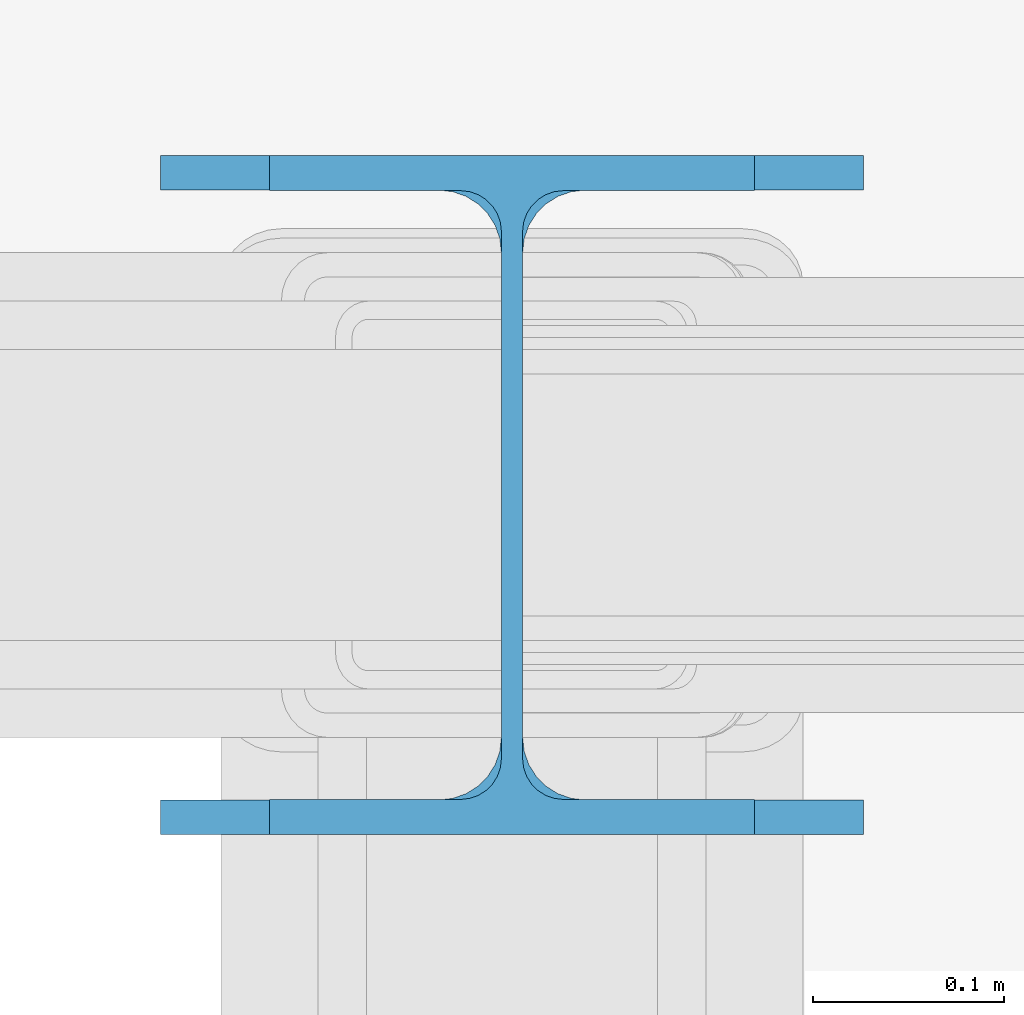
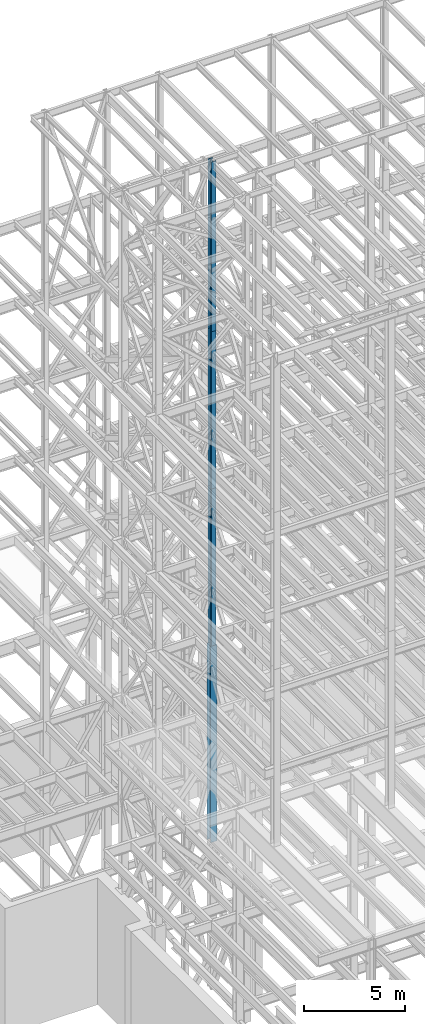
# One storey, part 17 of 150: 4 columns.
"""IFC2X3 building model written with IfcOpenShell, lengths in millimetres."""

from ifc_helpers import new_model, si_unit, frame, origin_with_axes, origin_2d_with_axis, place, context, subcontext, project, spatial, i_section, extrude, material, type_object, element, save


model = new_model("IFC2X3")

# Units and contexts
model_context = context("Model", 3, precision=1e-05, world=origin_with_axes())
body_context = subcontext(model_context, "Body", "Model", "MODEL_VIEW")
ifc_project = project(units=[si_unit("LENGTHUNIT", "METRE", prefix="MILLI"), si_unit("AREAUNIT", "SQUARE_METRE"), si_unit("VOLUMEUNIT", "CUBIC_METRE"), si_unit("MASSUNIT", "GRAM", prefix="KILO"), si_unit("TIMEUNIT", "SECOND"), si_unit("PLANEANGLEUNIT", "RADIAN"), si_unit("SOLIDANGLEUNIT", "STERADIAN"), si_unit("THERMODYNAMICTEMPERATUREUNIT", "DEGREE_CELSIUS"), si_unit("LUMINOUSINTENSITYUNIT", "LUMEN")], contexts=[model_context])

# Site, building, storey
site_placement = place(None, origin_with_axes())
site = spatial("IfcSite", under=ifc_project, at=site_placement, CompositionType="ELEMENT")
building_placement = place(site_placement, origin_with_axes())
building = spatial("IfcBuilding", under=site, at=building_placement, Name="Undefined", CompositionType="ELEMENT")
storey_placement = place(building_placement, origin_with_axes())
storey = spatial("IfcBuildingStorey", under=building, at=storey_placement, Name="Undefined", CompositionType="ELEMENT", Elevation=0.0)

# Columns
ifc_material = material(Name="STEEL/A992")
column_type_1 = type_object("IfcColumnType", Name="W14X68", PredefinedType="NOTDEFINED")
column_1_placement = place(storey_placement, frame((10312.39949708, 24384.0, 55702.2), z_axis=(0.0, 0.0, 1.0), x_axis=(1.0, 0.0, 0.0)))
element("IfcColumn", 1, at=column_1_placement, inside=storey, type_object=column_type_1, material=ifc_material, Name="COLUMN", ObjectType="W14X68", context=body_context, shape_type="SweptSolid", body=[
    extrude(i_section(OverallWidth=254.0, OverallDepth=355.6, WebThickness=11.1125, FlangeThickness=18.288, FilletRadius=21.3994, at=origin_2d_with_axis()), frame((0.0, 0.0, 10210.8), z_axis=(0.0, 0.0, -1.0), x_axis=(-1.0, 0.0, 0.0)), (0.0, 0.0, 1.0), 10210.8),
])
for number, where, z_axis, x_axis, name in (
    (2, (10312.39949708, 24384.0, 46253.4), (0.0, 0.0, 1.0), (1.0, 0.0, 0.0), "COLUMN"),
    (3, (10312.39949708, 24384.0, 36804.6), (0.0, 0.0, 1.0), (1.0, 0.0, 0.0), "COLUMN"),
):
    element("IfcColumn", number, at=place(storey_placement, frame(where, z_axis=z_axis, x_axis=x_axis)), inside=storey, type_object=column_type_1, material=ifc_material, Name=name, ObjectType="W14X68", context=body_context, shape_type="SweptSolid", body=[
        extrude(i_section(OverallWidth=254.0, OverallDepth=355.6, WebThickness=11.1125, FlangeThickness=18.288, FilletRadius=21.3994, at=origin_2d_with_axis()), frame((0.0, 0.0, 9448.8), z_axis=(0.0, 0.0, -1.0), x_axis=(-1.0, 0.0, 0.0)), (0.0, 0.0, 1.0), 9448.8),
    ])
column_type_2 = type_object("IfcColumnType", Name="W14X90", PredefinedType="NOTDEFINED")
column_2_placement = place(storey_placement, frame((10312.39949708, 24384.0, 24993.6), z_axis=(0.0, 0.0, 1.0), x_axis=(1.0, 0.0, 0.0)))
element("IfcColumn", 4, at=column_2_placement, inside=storey, type_object=column_type_2, material=ifc_material, Name="COLUMN", ObjectType="W14X90", context=body_context, shape_type="SweptSolid", body=[
    extrude(i_section(OverallWidth=368.3, OverallDepth=355.6, WebThickness=11.1125, FlangeThickness=18.034, FilletRadius=32.7659, at=origin_2d_with_axis()), frame((0.0, 0.0, 11811.0), z_axis=(0.0, 0.0, -1.0), x_axis=(-1.0, 0.0, 0.0)), (0.0, 0.0, 1.0), 11811.0),
])

save(model, "model.ifc")
